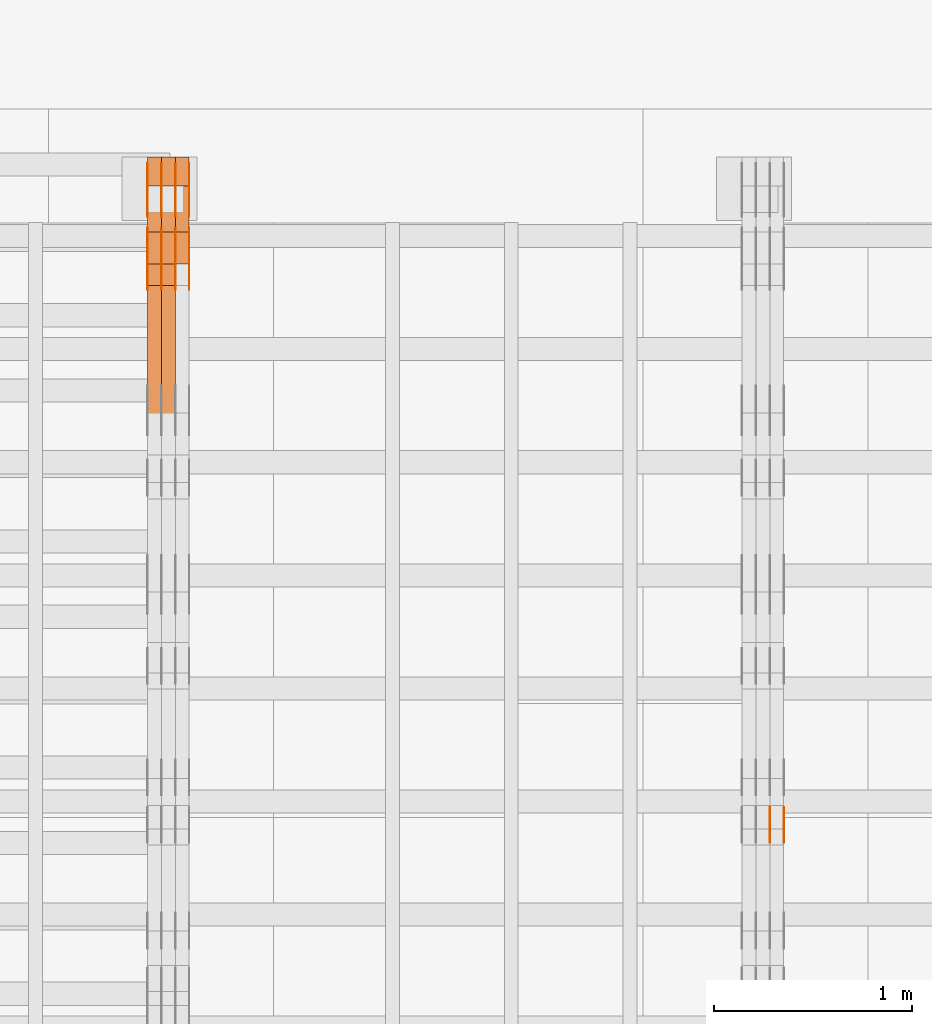
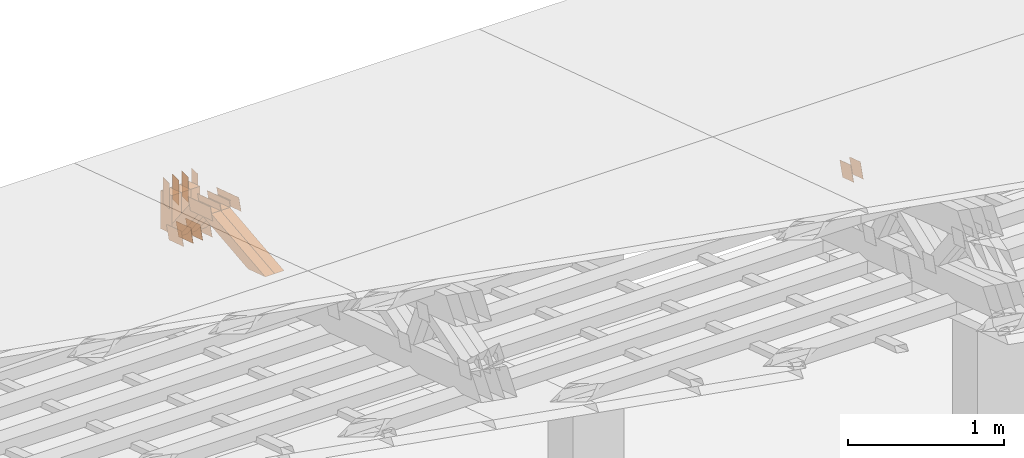
# One storey, part 186 of 385: 29 proxies.
"""IFC2X3 building model written with IfcOpenShell, lengths in millimetres."""

from ifc_helpers import new_model, entity, si_unit, converted_unit, derived_unit, direction, frame, frame_2d, origin, place, context, subcontext, project, spatial, polyline, rectangle, outline, extrude, source, transform, mapped, material, type_object, type_shapes, element, save


model = new_model("IFC2X3")

# Units and contexts
model_context = context("Model", 3, precision=0.01, world=origin(), true_north=direction((6.12303176911189e-17, 1.0)))
body_context = subcontext(model_context, "Body", "Model", "MODEL_VIEW")
ifc_project = project(units=[si_unit("LENGTHUNIT", "METRE", prefix="MILLI"), si_unit("AREAUNIT", "SQUARE_METRE"), si_unit("VOLUMEUNIT", "CUBIC_METRE"), converted_unit("PLANEANGLEUNIT", "DEGREE", entity("IfcRatioMeasure", 0.0174532925199433), si_unit("PLANEANGLEUNIT", "RADIAN"), dimensions=[0, 0, 0, 0, 0, 0, 0]), si_unit("MASSUNIT", "GRAM", prefix="KILO"), derived_unit("MASSDENSITYUNIT", [(si_unit("MASSUNIT", "GRAM", prefix="KILO"), 1), (si_unit("LENGTHUNIT", "METRE"), -3)]), si_unit("TIMEUNIT", "SECOND"), si_unit("FREQUENCYUNIT", "HERTZ"), si_unit("THERMODYNAMICTEMPERATUREUNIT", "DEGREE_CELSIUS"), derived_unit("THERMALTRANSMITTANCEUNIT", [(si_unit("MASSUNIT", "GRAM", prefix="KILO"), 1), (si_unit("THERMODYNAMICTEMPERATUREUNIT", "KELVIN"), -1), (si_unit("TIMEUNIT", "SECOND"), -3)]), derived_unit("VOLUMETRICFLOWRATEUNIT", [(si_unit("LENGTHUNIT", "METRE"), 3), (si_unit("TIMEUNIT", "SECOND"), -1)]), si_unit("ELECTRICCURRENTUNIT", "AMPERE"), si_unit("ELECTRICVOLTAGEUNIT", "VOLT"), si_unit("POWERUNIT", "WATT"), si_unit("FORCEUNIT", "NEWTON", prefix="KILO"), si_unit("ILLUMINANCEUNIT", "LUX"), si_unit("LUMINOUSFLUXUNIT", "LUMEN"), si_unit("LUMINOUSINTENSITYUNIT", "CANDELA"), derived_unit("USERDEFINED", [(si_unit("MASSUNIT", "GRAM", prefix="KILO"), -1), (si_unit("LENGTHUNIT", "METRE"), -2), (si_unit("TIMEUNIT", "SECOND"), 3), (si_unit("LUMINOUSFLUXUNIT", "LUMEN"), 1)]), derived_unit("LINEARVELOCITYUNIT", [(si_unit("LENGTHUNIT", "METRE"), 1), (si_unit("TIMEUNIT", "SECOND"), -1)]), si_unit("PRESSUREUNIT", "PASCAL"), derived_unit("USERDEFINED", [(si_unit("LENGTHUNIT", "METRE"), -2), (si_unit("MASSUNIT", "GRAM", prefix="KILO"), 1), (si_unit("TIMEUNIT", "SECOND"), -2)])], contexts=[model_context])

# Site, building, storey
site_placement = place(None, origin())
site = spatial("IfcSite", under=ifc_project, at=site_placement, CompositionType="ELEMENT")
building_placement = place(site_placement, origin())
building = spatial("IfcBuilding", under=site, at=building_placement, CompositionType="ELEMENT")
storey_placement = place(building_placement, origin())
storey = spatial("IfcBuildingStorey", under=building, at=storey_placement, Name="Default", CompositionType="ELEMENT", Elevation=0.0)

# Proxies
ifc_material_1 = material(Name="IfcSurfaceStyle #93190")
building_element_proxy_type_1 = type_object("IfcBuildingElementProxyType", PredefinedType="NOTDEFINED", material=ifc_material_1)
shared_shape_1 = source(origin(), body_context, "Body", "SweptSolid", [
    extrude(outline(polyline([(-74.9998888504569, -59.9999264677525), (74.999884859074, -59.9999264677525), (74.9998699895559, 59.9999264677525), (-74.999865998173, 59.9999264677525), (-74.9998888504569, -59.9999264677525)])), frame((74.9999170714918, 60.0000016373507, 0.0), z_axis=(0.0, 0.0, 1.0), x_axis=(-1.0, 0.0, 0.0)), (0.0, 0.0, 1.0), 1.3),
])
type_shapes(building_element_proxy_type_1, [shared_shape_1])
proxy_1_placement = place(building_placement, frame((6386.29999999999, 23182.5962361838, 1409.76695322432), z_axis=(-1.0, 0.0, 0.0), x_axis=(0.0, -0.951056516295154, 0.309016994374948)))
element("IfcBuildingElementProxy", 1, at=proxy_1_placement, inside=storey, type_object=building_element_proxy_type_1, material=ifc_material_1, context=body_context, shape_type="MappedRepresentation", body=[
    mapped(shared_shape_1, transform((0.0, 0.0, 0.0), scale=1.0)),
])
ifc_material_2 = material(Name="IfcSurfaceStyle #93133")
building_element_proxy_type_2 = type_object("IfcBuildingElementProxyType", PredefinedType="NOTDEFINED", material=ifc_material_2)
shared_shape_2 = source(origin(), body_context, "Body", "SweptSolid", [
    extrude(outline(polyline([(-74.9998888504569, -59.9999264677525), (74.999884859074, -59.9999264677525), (74.9998699895559, 59.9999264677525), (-74.999865998173, 59.9999264677525), (-74.9998888504569, -59.9999264677525)])), frame((74.9999170714918, 60.0000016373507, 0.0), z_axis=(0.0, 0.0, 1.0), x_axis=(-1.0, 0.0, 0.0)), (0.0, 0.0, 1.0), 1.3),
])
type_shapes(building_element_proxy_type_2, [shared_shape_2])
proxy_2_placement = place(building_placement, frame((6315.0, 23182.5962361838, 1409.76695322432), z_axis=(-1.0, 0.0, 0.0), x_axis=(0.0, -0.951056516295154, 0.309016994374948)))
element("IfcBuildingElementProxy", 2, at=proxy_2_placement, inside=storey, type_object=building_element_proxy_type_2, material=ifc_material_2, context=body_context, shape_type="MappedRepresentation", body=[
    mapped(shared_shape_2, transform((0.0, 0.0, 0.0), scale=1.0)),
])
ifc_material_3 = material(Name="IfcSurfaceStyle #93076")
building_element_proxy_type_3 = type_object("IfcBuildingElementProxyType", PredefinedType="NOTDEFINED", material=ifc_material_3)
shared_shape_3 = source(origin(), body_context, "Body", "SweptSolid", [
    extrude(outline(polyline([(-74.9998888504569, -59.9999264677525), (74.999884859074, -59.9999264677525), (74.9998699895559, 59.9999264677525), (-74.999865998173, 59.9999264677525), (-74.9998888504569, -59.9999264677525)])), frame((74.9999170714918, 60.0000016373507, 0.0), z_axis=(0.0, 0.0, 1.0), x_axis=(-1.0, 0.0, 0.0)), (0.0, 0.0, 1.0), 1.3),
])
type_shapes(building_element_proxy_type_3, [shared_shape_3])
proxy_3_placement = place(building_placement, frame((6316.29999999999, 23182.5962361838, 1409.76695322432), z_axis=(-1.0, 0.0, 0.0), x_axis=(0.0, -0.951056516295154, 0.309016994374948)))
element("IfcBuildingElementProxy", 3, at=proxy_3_placement, inside=storey, type_object=building_element_proxy_type_3, material=ifc_material_3, context=body_context, shape_type="MappedRepresentation", body=[
    mapped(shared_shape_3, transform((0.0, 0.0, 0.0), scale=1.0)),
])
ifc_material_4 = material(Name="IfcSurfaceStyle #68334")
building_element_proxy_type_4 = type_object("IfcBuildingElementProxyType", PredefinedType="NOTDEFINED", material=ifc_material_4)
shared_shape_4 = source(origin(), body_context, "Body", "SweptSolid", [
    extrude(outline(polyline([(-100.000024997547, -54.0000105875654), (100.000088940899, -54.0000105875654), (99.9999100805868, 54.0000105875654), (-99.9999740239394, 54.0000105875654), (-100.000024997547, -54.0000105875654)])), frame((100.000088940899, 54.0000474633838, 0.0), z_axis=(0.0, 0.0, 1.0), x_axis=(-1.0, 0.0, 0.0)), (0.0, 0.0, 1.0), 1.3),
])
type_shapes(building_element_proxy_type_4, [shared_shape_4])
proxy_4_placement = place(building_placement, frame((3386.29999999999, 26390.6212638563, 73.3227520411355), z_axis=(-1.0, 0.0, 0.0), x_axis=(0.0, -0.951056516295124, 0.309016994375039)))
element("IfcBuildingElementProxy", 4, at=proxy_4_placement, inside=storey, type_object=building_element_proxy_type_4, material=ifc_material_4, context=body_context, shape_type="MappedRepresentation", body=[
    mapped(shared_shape_4, transform((0.0, 0.0, 0.0), scale=1.0)),
])
ifc_material_5 = material(Name="IfcSurfaceStyle #68277")
building_element_proxy_type_5 = type_object("IfcBuildingElementProxyType", PredefinedType="NOTDEFINED", material=ifc_material_5)
shared_shape_5 = source(origin(), body_context, "Body", "SweptSolid", [
    extrude(outline(polyline([(-100.000024997547, -54.0000105875654), (100.000088940899, -54.0000105875654), (99.9999100805868, 54.0000105875654), (-99.9999740239394, 54.0000105875654), (-100.000024997547, -54.0000105875654)])), frame((100.000088940899, 54.0000474633838, 0.0), z_axis=(0.0, 0.0, 1.0), x_axis=(-1.0, 0.0, 0.0)), (0.0, 0.0, 1.0), 1.3),
])
type_shapes(building_element_proxy_type_5, [shared_shape_5])
proxy_5_placement = place(building_placement, frame((3315.0, 26390.6212638563, 73.3227520411355), z_axis=(-1.0, 0.0, 0.0), x_axis=(0.0, -0.951056516295124, 0.309016994375039)))
element("IfcBuildingElementProxy", 5, at=proxy_5_placement, inside=storey, type_object=building_element_proxy_type_5, material=ifc_material_5, context=body_context, shape_type="MappedRepresentation", body=[
    mapped(shared_shape_5, transform((0.0, 0.0, 0.0), scale=1.0)),
])
ifc_material_6 = material(Name="IfcSurfaceStyle #68220")
building_element_proxy_type_6 = type_object("IfcBuildingElementProxyType", PredefinedType="NOTDEFINED", material=ifc_material_6)
shared_shape_6 = source(origin(), body_context, "Body", "SweptSolid", [
    extrude(outline(polyline([(-100.000024997547, -54.0000105875654), (100.000088940899, -54.0000105875654), (99.9999100805868, 54.0000105875654), (-99.9999740239394, 54.0000105875654), (-100.000024997547, -54.0000105875654)])), frame((100.000088940899, 54.0000474633838, 0.0), z_axis=(0.0, 0.0, 1.0), x_axis=(-1.0, 0.0, 0.0)), (0.0, 0.0, 1.0), 1.3),
])
type_shapes(building_element_proxy_type_6, [shared_shape_6])
proxy_6_placement = place(building_placement, frame((3316.29999999999, 26390.6212638563, 73.3227520411355), z_axis=(-1.0, 0.0, 0.0), x_axis=(0.0, -0.951056516295124, 0.309016994375039)))
element("IfcBuildingElementProxy", 6, at=proxy_6_placement, inside=storey, type_object=building_element_proxy_type_6, material=ifc_material_6, context=body_context, shape_type="MappedRepresentation", body=[
    mapped(shared_shape_6, transform((0.0, 0.0, 0.0), scale=1.0)),
])
ifc_material_7 = material(Name="IfcSurfaceStyle #68163")
building_element_proxy_type_7 = type_object("IfcBuildingElementProxyType", PredefinedType="NOTDEFINED", material=ifc_material_7)
shared_shape_7 = source(origin(), body_context, "Body", "SweptSolid", [
    extrude(outline(polyline([(-100.000024997547, -54.0000105875654), (100.000088940899, -54.0000105875654), (99.9999100805868, 54.0000105875654), (-99.9999740239394, 54.0000105875654), (-100.000024997547, -54.0000105875654)])), frame((100.000088940899, 54.0000474633838, 0.0), z_axis=(0.0, 0.0, 1.0), x_axis=(-1.0, 0.0, 0.0)), (0.0, 0.0, 1.0), 1.29999999999998),
])
type_shapes(building_element_proxy_type_7, [shared_shape_7])
proxy_7_placement = place(building_placement, frame((3245.0, 26390.6212638563, 73.3227520411355), z_axis=(-1.0, 0.0, 0.0), x_axis=(0.0, -0.951056516295124, 0.309016994375039)))
element("IfcBuildingElementProxy", 7, at=proxy_7_placement, inside=storey, type_object=building_element_proxy_type_7, material=ifc_material_7, context=body_context, shape_type="MappedRepresentation", body=[
    mapped(shared_shape_7, transform((0.0, 0.0, 0.0), scale=1.0)),
])
ifc_material_8 = material(Name="IfcSurfaceStyle #68106")
building_element_proxy_type_8 = type_object("IfcBuildingElementProxyType", PredefinedType="NOTDEFINED", material=ifc_material_8)
shared_shape_8 = source(origin(), body_context, "Body", "SweptSolid", [
    extrude(outline(polyline([(-100.000024997547, -54.0000105875654), (100.000088940899, -54.0000105875654), (99.9999100805868, 54.0000105875654), (-99.9999740239394, 54.0000105875654), (-100.000024997547, -54.0000105875654)])), frame((100.000088940899, 54.0000474633838, 0.0), z_axis=(0.0, 0.0, 1.0), x_axis=(-1.0, 0.0, 0.0)), (0.0, 0.0, 1.0), 1.29999999999998),
])
type_shapes(building_element_proxy_type_8, [shared_shape_8])
proxy_8_placement = place(building_placement, frame((3246.29999999999, 26390.6212638563, 73.3227520411355), z_axis=(-1.0, 0.0, 0.0), x_axis=(0.0, -0.951056516295124, 0.309016994375039)))
element("IfcBuildingElementProxy", 8, at=proxy_8_placement, inside=storey, type_object=building_element_proxy_type_8, material=ifc_material_8, context=body_context, shape_type="MappedRepresentation", body=[
    mapped(shared_shape_8, transform((0.0, 0.0, 0.0), scale=1.0)),
])
ifc_material_9 = material(Name="IfcSurfaceStyle #68049")
building_element_proxy_type_9 = type_object("IfcBuildingElementProxyType", PredefinedType="NOTDEFINED", material=ifc_material_9)
shared_shape_9 = source(origin(), body_context, "Body", "SweptSolid", [
    extrude(outline(polyline([(-100.000024997547, -54.0000105875654), (100.000088940899, -54.0000105875654), (99.9999100805868, 54.0000105875654), (-99.9999740239394, 54.0000105875654), (-100.000024997547, -54.0000105875654)])), frame((100.000088940899, 54.0000474633838, 0.0), z_axis=(0.0, 0.0, 1.0), x_axis=(-1.0, 0.0, 0.0)), (0.0, 0.0, 1.0), 1.29999999999999),
])
type_shapes(building_element_proxy_type_9, [shared_shape_9])
proxy_9_placement = place(building_placement, frame((3175.0, 26390.6212638563, 73.3227520411355), z_axis=(-1.0, 0.0, 0.0), x_axis=(0.0, -0.951056516295124, 0.309016994375039)))
element("IfcBuildingElementProxy", 9, at=proxy_9_placement, inside=storey, type_object=building_element_proxy_type_9, material=ifc_material_9, context=body_context, shape_type="MappedRepresentation", body=[
    mapped(shared_shape_9, transform((0.0, 0.0, 0.0), scale=1.0)),
])
ifc_material_10 = material(Name="IfcSurfaceStyle #55680")
building_element_proxy_type_10 = type_object("IfcBuildingElementProxyType", PredefinedType="NOTDEFINED", material=ifc_material_10)
shared_shape_10 = source(origin(), body_context, "Body", "SweptSolid", [
    extrude(outline(polyline([(-149.999901061401, -48.0000057587028), (150.000035297123, -48.0000057587028), (149.999910491851, 48.0000057587028), (-150.000044727574, 48.0000057587028), (-149.999901061401, -48.0000057587028)])), frame((150.000035297123, 48.0000632585775, 0.0), z_axis=(0.0, 0.0, 1.0), x_axis=(-1.0, 0.0, 0.0)), (0.0, 0.0, 1.0), 1.29999999999999),
])
type_shapes(building_element_proxy_type_10, [shared_shape_10])
proxy_10_placement = place(building_placement, frame((3386.29999999999, 26115.0176968219, 469.58296924555), z_axis=(-1.0, 0.0, 0.0), x_axis=(0.0, -0.951056516295154, 0.309016994374948)))
element("IfcBuildingElementProxy", 10, at=proxy_10_placement, inside=storey, type_object=building_element_proxy_type_10, material=ifc_material_10, context=body_context, shape_type="MappedRepresentation", body=[
    mapped(shared_shape_10, transform((0.0, 0.0, 0.0), scale=1.0)),
])
ifc_material_11 = material(Name="IfcSurfaceStyle #55623")
building_element_proxy_type_11 = type_object("IfcBuildingElementProxyType", PredefinedType="NOTDEFINED", material=ifc_material_11)
shared_shape_11 = source(origin(), body_context, "Body", "SweptSolid", [
    extrude(outline(polyline([(-149.999901061401, -48.0000057587028), (150.000035297123, -48.0000057587028), (149.999910491851, 48.0000057587028), (-150.000044727574, 48.0000057587028), (-149.999901061401, -48.0000057587028)])), frame((150.000035297123, 48.0000632585775, 0.0), z_axis=(0.0, 0.0, 1.0), x_axis=(-1.0, 0.0, 0.0)), (0.0, 0.0, 1.0), 1.29999999999999),
])
type_shapes(building_element_proxy_type_11, [shared_shape_11])
proxy_11_placement = place(building_placement, frame((3315.0, 26115.0176968219, 469.58296924555), z_axis=(-1.0, 0.0, 0.0), x_axis=(0.0, -0.951056516295154, 0.309016994374948)))
element("IfcBuildingElementProxy", 11, at=proxy_11_placement, inside=storey, type_object=building_element_proxy_type_11, material=ifc_material_11, context=body_context, shape_type="MappedRepresentation", body=[
    mapped(shared_shape_11, transform((0.0, 0.0, 0.0), scale=1.0)),
])
ifc_material_12 = material(Name="IfcSurfaceStyle #55566")
building_element_proxy_type_12 = type_object("IfcBuildingElementProxyType", PredefinedType="NOTDEFINED", material=ifc_material_12)
shared_shape_12 = source(origin(), body_context, "Body", "SweptSolid", [
    extrude(outline(polyline([(-149.999901061401, -48.0000057587028), (150.000035297123, -48.0000057587028), (149.999910491851, 48.0000057587028), (-150.000044727574, 48.0000057587028), (-149.999901061401, -48.0000057587028)])), frame((150.000035297123, 48.0000632585775, 0.0), z_axis=(0.0, 0.0, 1.0), x_axis=(-1.0, 0.0, 0.0)), (0.0, 0.0, 1.0), 1.29999999999999),
])
type_shapes(building_element_proxy_type_12, [shared_shape_12])
proxy_12_placement = place(building_placement, frame((3316.29999999999, 26115.0176968219, 469.58296924555), z_axis=(-1.0, 0.0, 0.0), x_axis=(0.0, -0.951056516295154, 0.309016994374948)))
element("IfcBuildingElementProxy", 12, at=proxy_12_placement, inside=storey, type_object=building_element_proxy_type_12, material=ifc_material_12, context=body_context, shape_type="MappedRepresentation", body=[
    mapped(shared_shape_12, transform((0.0, 0.0, 0.0), scale=1.0)),
])
ifc_material_13 = material(Name="IfcSurfaceStyle #55509")
building_element_proxy_type_13 = type_object("IfcBuildingElementProxyType", PredefinedType="NOTDEFINED", material=ifc_material_13)
shared_shape_13 = source(origin(), body_context, "Body", "SweptSolid", [
    extrude(outline(polyline([(-149.999901061401, -48.0000057587028), (150.000035297123, -48.0000057587028), (149.999910491851, 48.0000057587028), (-150.000044727574, 48.0000057587028), (-149.999901061401, -48.0000057587028)])), frame((150.000035297123, 48.0000632585775, 0.0), z_axis=(0.0, 0.0, 1.0), x_axis=(-1.0, 0.0, 0.0)), (0.0, 0.0, 1.0), 1.29999999999998),
])
type_shapes(building_element_proxy_type_13, [shared_shape_13])
proxy_13_placement = place(building_placement, frame((3245.0, 26115.0176968219, 469.58296924555), z_axis=(-1.0, 0.0, 0.0), x_axis=(0.0, -0.951056516295154, 0.309016994374948)))
element("IfcBuildingElementProxy", 13, at=proxy_13_placement, inside=storey, type_object=building_element_proxy_type_13, material=ifc_material_13, context=body_context, shape_type="MappedRepresentation", body=[
    mapped(shared_shape_13, transform((0.0, 0.0, 0.0), scale=1.0)),
])
ifc_material_14 = material(Name="IfcSurfaceStyle #55452")
building_element_proxy_type_14 = type_object("IfcBuildingElementProxyType", PredefinedType="NOTDEFINED", material=ifc_material_14)
shared_shape_14 = source(origin(), body_context, "Body", "SweptSolid", [
    extrude(outline(polyline([(-149.999901061401, -48.0000057587028), (150.000035297123, -48.0000057587028), (149.999910491851, 48.0000057587028), (-150.000044727574, 48.0000057587028), (-149.999901061401, -48.0000057587028)])), frame((150.000035297123, 48.0000632585775, 0.0), z_axis=(0.0, 0.0, 1.0), x_axis=(-1.0, 0.0, 0.0)), (0.0, 0.0, 1.0), 1.29999999999998),
])
type_shapes(building_element_proxy_type_14, [shared_shape_14])
proxy_14_placement = place(building_placement, frame((3246.29999999999, 26115.0176968219, 469.58296924555), z_axis=(-1.0, 0.0, 0.0), x_axis=(0.0, -0.951056516295154, 0.309016994374948)))
element("IfcBuildingElementProxy", 14, at=proxy_14_placement, inside=storey, type_object=building_element_proxy_type_14, material=ifc_material_14, context=body_context, shape_type="MappedRepresentation", body=[
    mapped(shared_shape_14, transform((0.0, 0.0, 0.0), scale=1.0)),
])
ifc_material_15 = material(Name="IfcSurfaceStyle #55395")
building_element_proxy_type_15 = type_object("IfcBuildingElementProxyType", PredefinedType="NOTDEFINED", material=ifc_material_15)
shared_shape_15 = source(origin(), body_context, "Body", "SweptSolid", [
    extrude(outline(polyline([(-149.999901061401, -48.0000057587028), (150.000035297123, -48.0000057587028), (149.999910491851, 48.0000057587028), (-150.000044727574, 48.0000057587028), (-149.999901061401, -48.0000057587028)])), frame((150.000035297123, 48.0000632585775, 0.0), z_axis=(0.0, 0.0, 1.0), x_axis=(-1.0, 0.0, 0.0)), (0.0, 0.0, 1.0), 1.29999999999998),
])
type_shapes(building_element_proxy_type_15, [shared_shape_15])
proxy_15_placement = place(building_placement, frame((3175.0, 26115.0176968219, 469.58296924555), z_axis=(-1.0, 0.0, 0.0), x_axis=(0.0, -0.951056516295154, 0.309016994374948)))
element("IfcBuildingElementProxy", 15, at=proxy_15_placement, inside=storey, type_object=building_element_proxy_type_15, material=ifc_material_15, context=body_context, shape_type="MappedRepresentation", body=[
    mapped(shared_shape_15, transform((0.0, 0.0, 0.0), scale=1.0)),
])
ifc_material_16 = material(Name="IfcSurfaceStyle #55338")
building_element_proxy_type_16 = type_object("IfcBuildingElementProxyType", PredefinedType="NOTDEFINED", material=ifc_material_16)
shared_shape_16 = source(origin(), body_context, "Body", "SweptSolid", [
    extrude(rectangle(XDim=200.0, YDim=84.0000000000005, at=frame_2d((-2.1316282072803e-14, 1.06581410364015e-14), x_axis=(1.0, 0.0))), frame((100.0, 42.0, 0.0), z_axis=(0.0, 0.0, 1.0), x_axis=(-1.0, 0.0, 0.0)), (0.0, 0.0, 1.0), 1.3),
])
type_shapes(building_element_proxy_type_16, [shared_shape_16])
proxy_16_placement = place(building_placement, frame((3386.29999999999, 26469.5000000002, 518.521545410156), z_axis=(-1.0, 0.0, 0.0), x_axis=(0.0, 0.0, -1.0)))
element("IfcBuildingElementProxy", 16, at=proxy_16_placement, inside=storey, type_object=building_element_proxy_type_16, material=ifc_material_16, context=body_context, shape_type="MappedRepresentation", body=[
    mapped(shared_shape_16, transform((0.0, 0.0, 0.0), scale=1.0)),
])
ifc_material_17 = material(Name="IfcSurfaceStyle #55281")
building_element_proxy_type_17 = type_object("IfcBuildingElementProxyType", PredefinedType="NOTDEFINED", material=ifc_material_17)
shared_shape_17 = source(origin(), body_context, "Body", "SweptSolid", [
    extrude(rectangle(XDim=200.0, YDim=84.0000000000005, at=frame_2d((-2.1316282072803e-14, 1.06581410364015e-14), x_axis=(1.0, 0.0))), frame((100.0, 42.0, 0.0), z_axis=(0.0, 0.0, 1.0), x_axis=(-1.0, 0.0, 0.0)), (0.0, 0.0, 1.0), 1.3),
])
type_shapes(building_element_proxy_type_17, [shared_shape_17])
proxy_17_placement = place(building_placement, frame((3315.0, 26469.5000000002, 518.521545410156), z_axis=(-1.0, 0.0, 0.0), x_axis=(0.0, 0.0, -1.0)))
element("IfcBuildingElementProxy", 17, at=proxy_17_placement, inside=storey, type_object=building_element_proxy_type_17, material=ifc_material_17, context=body_context, shape_type="MappedRepresentation", body=[
    mapped(shared_shape_17, transform((0.0, 0.0, 0.0), scale=1.0)),
])
ifc_material_18 = material(Name="IfcSurfaceStyle #55224")
building_element_proxy_type_18 = type_object("IfcBuildingElementProxyType", PredefinedType="NOTDEFINED", material=ifc_material_18)
shared_shape_18 = source(origin(), body_context, "Body", "SweptSolid", [
    extrude(rectangle(XDim=200.0, YDim=84.0000000000005, at=frame_2d((-2.1316282072803e-14, 1.06581410364015e-14), x_axis=(1.0, 0.0))), frame((100.0, 42.0, 0.0), z_axis=(0.0, 0.0, 1.0), x_axis=(-1.0, 0.0, 0.0)), (0.0, 0.0, 1.0), 1.3),
])
type_shapes(building_element_proxy_type_18, [shared_shape_18])
proxy_18_placement = place(building_placement, frame((3316.29999999999, 26469.5000000002, 518.521545410156), z_axis=(-1.0, 0.0, 0.0), x_axis=(0.0, 0.0, -1.0)))
element("IfcBuildingElementProxy", 18, at=proxy_18_placement, inside=storey, type_object=building_element_proxy_type_18, material=ifc_material_18, context=body_context, shape_type="MappedRepresentation", body=[
    mapped(shared_shape_18, transform((0.0, 0.0, 0.0), scale=1.0)),
])
ifc_material_19 = material(Name="IfcSurfaceStyle #55167")
building_element_proxy_type_19 = type_object("IfcBuildingElementProxyType", PredefinedType="NOTDEFINED", material=ifc_material_19)
shared_shape_19 = source(origin(), body_context, "Body", "SweptSolid", [
    extrude(rectangle(XDim=200.0, YDim=84.0000000000005, at=frame_2d((-2.1316282072803e-14, 1.06581410364015e-14), x_axis=(1.0, 0.0))), frame((100.0, 42.0, 0.0), z_axis=(0.0, 0.0, 1.0), x_axis=(-1.0, 0.0, 0.0)), (0.0, 0.0, 1.0), 1.29999999999998),
])
type_shapes(building_element_proxy_type_19, [shared_shape_19])
proxy_19_placement = place(building_placement, frame((3245.0, 26469.5000000002, 518.521545410156), z_axis=(-1.0, 0.0, 0.0), x_axis=(0.0, 0.0, -1.0)))
element("IfcBuildingElementProxy", 19, at=proxy_19_placement, inside=storey, type_object=building_element_proxy_type_19, material=ifc_material_19, context=body_context, shape_type="MappedRepresentation", body=[
    mapped(shared_shape_19, transform((0.0, 0.0, 0.0), scale=1.0)),
])
ifc_material_20 = material(Name="IfcSurfaceStyle #55110")
building_element_proxy_type_20 = type_object("IfcBuildingElementProxyType", PredefinedType="NOTDEFINED", material=ifc_material_20)
shared_shape_20 = source(origin(), body_context, "Body", "SweptSolid", [
    extrude(rectangle(XDim=200.0, YDim=84.0000000000005, at=frame_2d((-2.1316282072803e-14, 1.06581410364015e-14), x_axis=(1.0, 0.0))), frame((100.0, 42.0, 0.0), z_axis=(0.0, 0.0, 1.0), x_axis=(-1.0, 0.0, 0.0)), (0.0, 0.0, 1.0), 1.29999999999998),
])
type_shapes(building_element_proxy_type_20, [shared_shape_20])
proxy_20_placement = place(building_placement, frame((3246.29999999999, 26469.5000000002, 518.521545410156), z_axis=(-1.0, 0.0, 0.0), x_axis=(0.0, 0.0, -1.0)))
element("IfcBuildingElementProxy", 20, at=proxy_20_placement, inside=storey, type_object=building_element_proxy_type_20, material=ifc_material_20, context=body_context, shape_type="MappedRepresentation", body=[
    mapped(shared_shape_20, transform((0.0, 0.0, 0.0), scale=1.0)),
])
ifc_material_21 = material(Name="IfcSurfaceStyle #55053")
building_element_proxy_type_21 = type_object("IfcBuildingElementProxyType", PredefinedType="NOTDEFINED", material=ifc_material_21)
shared_shape_21 = source(origin(), body_context, "Body", "SweptSolid", [
    extrude(rectangle(XDim=200.0, YDim=84.0000000000005, at=frame_2d((-2.1316282072803e-14, 1.06581410364015e-14), x_axis=(1.0, 0.0))), frame((100.0, 42.0, 0.0), z_axis=(0.0, 0.0, 1.0), x_axis=(-1.0, 0.0, 0.0)), (0.0, 0.0, 1.0), 1.29999999999999),
])
type_shapes(building_element_proxy_type_21, [shared_shape_21])
proxy_21_placement = place(building_placement, frame((3175.0, 26469.5000000002, 518.521545410156), z_axis=(-1.0, 0.0, 0.0), x_axis=(0.0, 0.0, -1.0)))
element("IfcBuildingElementProxy", 21, at=proxy_21_placement, inside=storey, type_object=building_element_proxy_type_21, material=ifc_material_21, context=body_context, shape_type="MappedRepresentation", body=[
    mapped(shared_shape_21, transform((0.0, 0.0, 0.0), scale=1.0)),
])
ifc_material_22 = material(Name="IfcSurfaceStyle #43860")
building_element_proxy_type_22 = type_object("IfcBuildingElementProxyType", Name="T1-W4 43858", PredefinedType="NOTDEFINED", material=ifc_material_22)
shared_shape_22 = source(origin(), body_context, "Body", "SweptSolid", [
    extrude(outline(polyline([(-510.077325435179, -47.4999981284922), (188.854793418912, -47.4999981284922), (294.906688207675, 1.67015383116809e-05), (324.289382923648, 47.499989777723), (-297.973539115057, 47.4999897777231), (-510.077325435179, -47.4999981284922)])), frame((324.289382923648, 47.5000278316275, 0.0), z_axis=(0.0, 0.0, 1.0), x_axis=(-1.0, 0.0, 0.0)), (0.0, 0.0, 1.0), 70.0),
])
type_shapes(building_element_proxy_type_22, [shared_shape_22])
proxy_22_placement = place(building_placement, frame((3315.0, 25996.2241251556, 525.69905884318), z_axis=(-1.0, 0.0, 0.0), x_axis=(0.0, -0.994287125203057, -0.106738524701444)))
element("IfcBuildingElementProxy", 22, at=proxy_22_placement, inside=storey, type_object=building_element_proxy_type_22, material=ifc_material_22, Name="T1-W4", context=body_context, shape_type="MappedRepresentation", body=[
    mapped(shared_shape_22, transform((0.0, 0.0, 0.0), scale=1.0)),
])
ifc_material_23 = material(Name="IfcSurfaceStyle #43794")
building_element_proxy_type_23 = type_object("IfcBuildingElementProxyType", Name="T1-W4 43792", PredefinedType="NOTDEFINED", material=ifc_material_23)
shared_shape_23 = source(origin(), body_context, "Body", "SweptSolid", [
    extrude(outline(polyline([(-510.077325435179, -47.4999981284922), (188.854793418912, -47.4999981284922), (294.906688207675, 1.67015383116809e-05), (324.289382923648, 47.499989777723), (-297.973539115057, 47.4999897777231), (-510.077325435179, -47.4999981284922)])), frame((324.289382923648, 47.5000278316275, 0.0), z_axis=(0.0, 0.0, 1.0), x_axis=(-1.0, 0.0, 0.0)), (0.0, 0.0, 1.0), 70.0),
])
type_shapes(building_element_proxy_type_23, [shared_shape_23])
proxy_23_placement = place(building_placement, frame((3245.0, 25996.2241251556, 525.69905884318), z_axis=(-1.0, 0.0, 0.0), x_axis=(0.0, -0.994287125203057, -0.106738524701444)))
element("IfcBuildingElementProxy", 23, at=proxy_23_placement, inside=storey, type_object=building_element_proxy_type_23, material=ifc_material_23, Name="T1-W4", context=body_context, shape_type="MappedRepresentation", body=[
    mapped(shared_shape_23, transform((0.0, 0.0, 0.0), scale=1.0)),
])
ifc_material_24 = material(Name="IfcSurfaceStyle #43530")
building_element_proxy_type_24 = type_object("IfcBuildingElementProxyType", Name="T1-W21 43528", PredefinedType="NOTDEFINED", material=ifc_material_24)
shared_shape_24 = source(origin(), body_context, "Body", "SweptSolid", [
    extrude(outline(polyline([(-209.199362597501, -47.5000308982766), (168.813164734153, -47.5000308982766), (229.900717355638, -2.18385470334148e-05), (159.828709317766, 47.5000418175501), (-349.343228810055, 47.5000418175502), (-209.199362597501, -47.5000308982766)])), frame((229.900720156071, 47.5000418175501, 0.0), z_axis=(0.0, 0.0, 1.0), x_axis=(-1.0, 0.0, 0.0)), (0.0, 0.0, 1.0), 70.0),
])
type_shapes(building_element_proxy_type_24, [shared_shape_24])
proxy_24_placement = place(building_placement, frame((3385.0, 26317.5019908272, 112.518372832984), z_axis=(-1.0, 0.0, 0.0), x_axis=(0.0, -0.613839629272042, 0.789430750310097)))
element("IfcBuildingElementProxy", 24, at=proxy_24_placement, inside=storey, type_object=building_element_proxy_type_24, material=ifc_material_24, Name="T1-W21", context=body_context, shape_type="MappedRepresentation", body=[
    mapped(shared_shape_24, transform((0.0, 0.0, 0.0), scale=1.0)),
])
ifc_material_25 = material(Name="IfcSurfaceStyle #43464")
building_element_proxy_type_25 = type_object("IfcBuildingElementProxyType", Name="T1-W21 43462", PredefinedType="NOTDEFINED", material=ifc_material_25)
shared_shape_25 = source(origin(), body_context, "Body", "SweptSolid", [
    extrude(outline(polyline([(-209.199362597501, -47.5000308982766), (168.813164734153, -47.5000308982766), (229.900717355638, -2.18385470334148e-05), (159.828709317766, 47.5000418175501), (-349.343228810055, 47.5000418175502), (-209.199362597501, -47.5000308982766)])), frame((229.900720156071, 47.5000418175501, 0.0), z_axis=(0.0, 0.0, 1.0), x_axis=(-1.0, 0.0, 0.0)), (0.0, 0.0, 1.0), 70.0),
])
type_shapes(building_element_proxy_type_25, [shared_shape_25])
proxy_25_placement = place(building_placement, frame((3315.0, 26317.5019908272, 112.518372832984), z_axis=(-1.0, 0.0, 0.0), x_axis=(0.0, -0.613839629272042, 0.789430750310097)))
element("IfcBuildingElementProxy", 25, at=proxy_25_placement, inside=storey, type_object=building_element_proxy_type_25, material=ifc_material_25, Name="T1-W21", context=body_context, shape_type="MappedRepresentation", body=[
    mapped(shared_shape_25, transform((0.0, 0.0, 0.0), scale=1.0)),
])
ifc_material_26 = material(Name="IfcSurfaceStyle #43398")
building_element_proxy_type_26 = type_object("IfcBuildingElementProxyType", Name="T1-W21 43396", PredefinedType="NOTDEFINED", material=ifc_material_26)
shared_shape_26 = source(origin(), body_context, "Body", "SweptSolid", [
    extrude(outline(polyline([(-209.199362597501, -47.5000308982766), (168.813164734153, -47.5000308982766), (229.900717355638, -2.18385470334148e-05), (159.828709317766, 47.5000418175501), (-349.343228810055, 47.5000418175502), (-209.199362597501, -47.5000308982766)])), frame((229.900720156071, 47.5000418175501, 0.0), z_axis=(0.0, 0.0, 1.0), x_axis=(-1.0, 0.0, 0.0)), (0.0, 0.0, 1.0), 70.0),
])
type_shapes(building_element_proxy_type_26, [shared_shape_26])
proxy_26_placement = place(building_placement, frame((3245.0, 26317.5019908272, 112.518372832984), z_axis=(-1.0, 0.0, 0.0), x_axis=(0.0, -0.613839629272042, 0.789430750310097)))
element("IfcBuildingElementProxy", 26, at=proxy_26_placement, inside=storey, type_object=building_element_proxy_type_26, material=ifc_material_26, Name="T1-W21", context=body_context, shape_type="MappedRepresentation", body=[
    mapped(shared_shape_26, transform((0.0, 0.0, 0.0), scale=1.0)),
])
ifc_material_27 = material(Name="IfcSurfaceStyle #42963")
building_element_proxy_type_27 = type_object("IfcBuildingElementProxyType", Name="T1-E2 42961", PredefinedType="NOTDEFINED", material=ifc_material_27)
shared_shape_27 = source(origin(), body_context, "Body", "SweptSolid", [
    extrude(outline(polyline([(-126.644535064697, -72.4999999999998), (173.757884979248, -72.4999999999998), (126.644542694092, 72.4999999999998), (-173.757892608642, 72.4999999999998), (-126.644535064697, -72.4999999999998)])), frame((173.757890653796, 72.5000000000002, 0.0), z_axis=(0.0, 0.0, 1.0), x_axis=(-1.0, 0.0, 0.0)), (0.0, 0.0, 1.0), 70.0),
])
type_shapes(building_element_proxy_type_27, [shared_shape_27])
proxy_27_placement = place(building_placement, frame((3385.0, 26500.0, 442.078222227283), z_axis=(-1.0, 0.0, 0.0), x_axis=(0.0, 0.0, -1.0)))
element("IfcBuildingElementProxy", 27, at=proxy_27_placement, inside=storey, type_object=building_element_proxy_type_27, material=ifc_material_27, Name="T1-E2", context=body_context, shape_type="MappedRepresentation", body=[
    mapped(shared_shape_27, transform((0.0, 0.0, 0.0), scale=1.0)),
])
ifc_material_28 = material(Name="IfcSurfaceStyle #42906")
building_element_proxy_type_28 = type_object("IfcBuildingElementProxyType", Name="T1-E2 42904", PredefinedType="NOTDEFINED", material=ifc_material_28)
shared_shape_28 = source(origin(), body_context, "Body", "SweptSolid", [
    extrude(outline(polyline([(-126.644535064697, -72.4999999999998), (173.757884979248, -72.4999999999998), (126.644542694092, 72.4999999999998), (-173.757892608642, 72.4999999999998), (-126.644535064697, -72.4999999999998)])), frame((173.757890653796, 72.5000000000002, 0.0), z_axis=(0.0, 0.0, 1.0), x_axis=(-1.0, 0.0, 0.0)), (0.0, 0.0, 1.0), 70.0),
])
type_shapes(building_element_proxy_type_28, [shared_shape_28])
proxy_28_placement = place(building_placement, frame((3315.0, 26500.0, 442.078222227283), z_axis=(-1.0, 0.0, 0.0), x_axis=(0.0, 0.0, -1.0)))
element("IfcBuildingElementProxy", 28, at=proxy_28_placement, inside=storey, type_object=building_element_proxy_type_28, material=ifc_material_28, Name="T1-E2", context=body_context, shape_type="MappedRepresentation", body=[
    mapped(shared_shape_28, transform((0.0, 0.0, 0.0), scale=1.0)),
])
ifc_material_29 = material(Name="IfcSurfaceStyle #42849")
building_element_proxy_type_29 = type_object("IfcBuildingElementProxyType", Name="T1-E2 42847", PredefinedType="NOTDEFINED", material=ifc_material_29)
shared_shape_29 = source(origin(), body_context, "Body", "SweptSolid", [
    extrude(outline(polyline([(-126.644535064697, -72.4999999999998), (173.757884979248, -72.4999999999998), (126.644542694092, 72.4999999999998), (-173.757892608642, 72.4999999999998), (-126.644535064697, -72.4999999999998)])), frame((173.757890653796, 72.5000000000002, 0.0), z_axis=(0.0, 0.0, 1.0), x_axis=(-1.0, 0.0, 0.0)), (0.0, 0.0, 1.0), 70.0),
])
type_shapes(building_element_proxy_type_29, [shared_shape_29])
proxy_29_placement = place(building_placement, frame((3245.0, 26500.0, 442.078222227283), z_axis=(-1.0, 0.0, 0.0), x_axis=(0.0, 0.0, -1.0)))
element("IfcBuildingElementProxy", 29, at=proxy_29_placement, inside=storey, type_object=building_element_proxy_type_29, material=ifc_material_29, Name="T1-E2", context=body_context, shape_type="MappedRepresentation", body=[
    mapped(shared_shape_29, transform((0.0, 0.0, 0.0), scale=1.0)),
])

save(model, "model.ifc")
